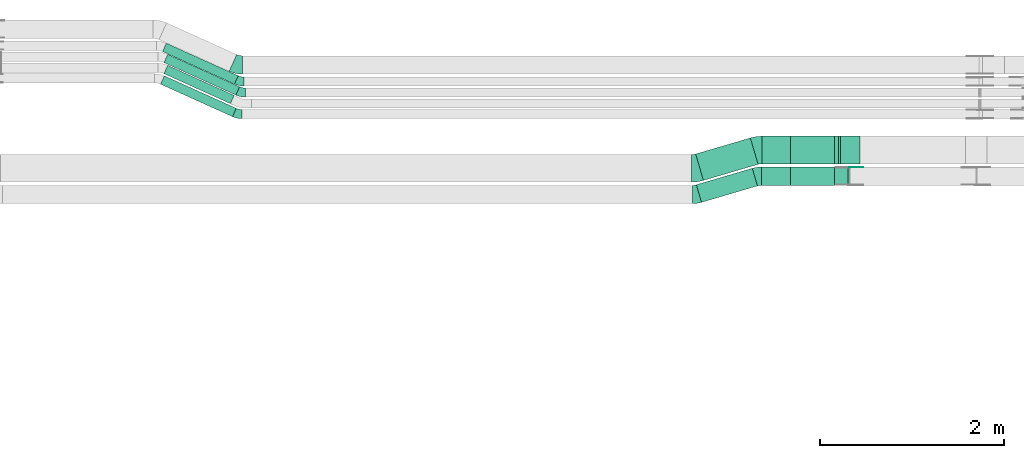
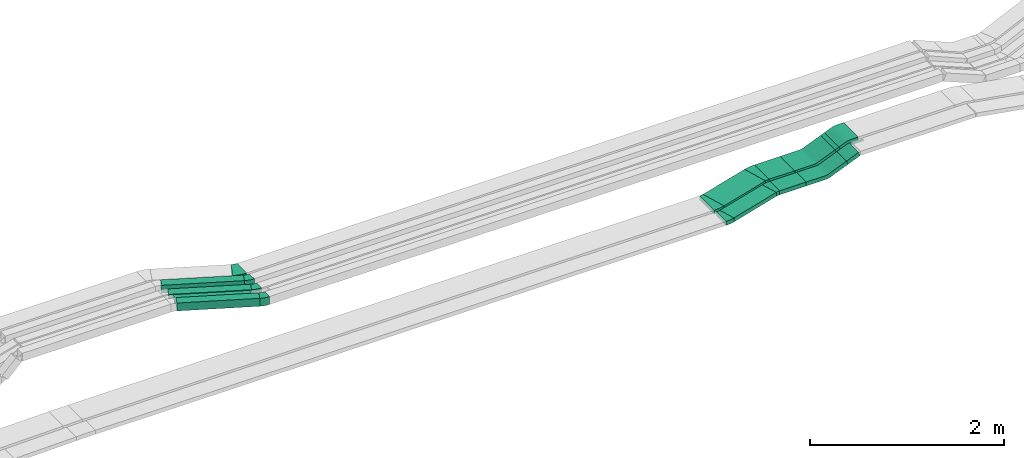
# One storey, part 14 of 31: 12 flow fittings, 10 flow segments.
"""IFC2X3 building model written with IfcOpenShell, lengths in millimetres."""

from ifc_helpers import new_model, entity, si_unit, converted_unit, derived_unit, direction, frame, frame_2d, origin, origin_2d_with_axis, place, context, subcontext, project, spatial, polyline, circle_curve, parameter, trimmed, segment, composite_curve, rectangle, outline, extrude, source, transform, mapped, material, type_object, type_shapes, element, save


model = new_model("IFC2X3")

# Units and contexts
model_context = context("Model", 3, precision=0.01, world=origin(), true_north=direction((6.12303176911189e-17, 1.0)))
body_context = subcontext(model_context, "Body", "Model", "MODEL_VIEW")
ifc_project = project(units=[si_unit("LENGTHUNIT", "METRE", prefix="MILLI"), si_unit("AREAUNIT", "SQUARE_METRE"), si_unit("VOLUMEUNIT", "CUBIC_METRE"), converted_unit("PLANEANGLEUNIT", "DEGREE", entity("IfcRatioMeasure", 0.0174532925199433), si_unit("PLANEANGLEUNIT", "RADIAN"), dimensions=[0, 0, 0, 0, 0, 0, 0]), si_unit("MASSUNIT", "GRAM", prefix="KILO"), derived_unit("MASSDENSITYUNIT", [(si_unit("MASSUNIT", "GRAM", prefix="KILO"), 1), (si_unit("LENGTHUNIT", "METRE"), -3)]), derived_unit("MOMENTOFINERTIAUNIT", [(si_unit("LENGTHUNIT", "METRE"), 4)]), si_unit("TIMEUNIT", "SECOND"), si_unit("FREQUENCYUNIT", "HERTZ"), si_unit("THERMODYNAMICTEMPERATUREUNIT", "DEGREE_CELSIUS"), derived_unit("THERMALTRANSMITTANCEUNIT", [(si_unit("MASSUNIT", "GRAM", prefix="KILO"), 1), (si_unit("THERMODYNAMICTEMPERATUREUNIT", "KELVIN"), -1), (si_unit("TIMEUNIT", "SECOND"), -3)]), derived_unit("VOLUMETRICFLOWRATEUNIT", [(si_unit("LENGTHUNIT", "METRE"), 3), (si_unit("TIMEUNIT", "SECOND"), -1)]), derived_unit("MASSFLOWRATEUNIT", [(si_unit("MASSUNIT", "GRAM", prefix="KILO"), 1), (si_unit("TIMEUNIT", "SECOND"), -1)]), derived_unit("ROTATIONALFREQUENCYUNIT", [(si_unit("TIMEUNIT", "SECOND"), -1)]), si_unit("ELECTRICCURRENTUNIT", "AMPERE"), si_unit("ELECTRICVOLTAGEUNIT", "VOLT"), si_unit("POWERUNIT", "WATT"), si_unit("FORCEUNIT", "NEWTON", prefix="KILO"), si_unit("ILLUMINANCEUNIT", "LUX"), si_unit("LUMINOUSFLUXUNIT", "LUMEN"), si_unit("LUMINOUSINTENSITYUNIT", "CANDELA"), derived_unit("USERDEFINED", [(si_unit("MASSUNIT", "GRAM", prefix="KILO"), -1), (si_unit("LENGTHUNIT", "METRE"), -2), (si_unit("TIMEUNIT", "SECOND"), 3), (si_unit("LUMINOUSFLUXUNIT", "LUMEN"), 1)]), derived_unit("LINEARVELOCITYUNIT", [(si_unit("LENGTHUNIT", "METRE"), 1), (si_unit("TIMEUNIT", "SECOND"), -1)]), si_unit("PRESSUREUNIT", "PASCAL"), derived_unit("USERDEFINED", [(si_unit("LENGTHUNIT", "METRE"), -2), (si_unit("MASSUNIT", "GRAM", prefix="KILO"), 1), (si_unit("TIMEUNIT", "SECOND"), -2)]), derived_unit("LINEARFORCEUNIT", [(si_unit("MASSUNIT", "GRAM", prefix="KILO"), 1), (si_unit("LENGTHUNIT", "METRE"), 1), (si_unit("TIMEUNIT", "SECOND"), -2), (si_unit("LENGTHUNIT", "METRE"), -1)]), derived_unit("PLANARFORCEUNIT", [(si_unit("MASSUNIT", "GRAM", prefix="KILO"), 1), (si_unit("LENGTHUNIT", "METRE"), 1), (si_unit("TIMEUNIT", "SECOND"), -2), (si_unit("LENGTHUNIT", "METRE"), -2)])], contexts=[model_context])

# Site, building, storey
site_placement = place(None, frame((0.0, -0.00077364408347762, 0.0)))
site = spatial("IfcSite", under=ifc_project, at=site_placement, CompositionType="ELEMENT")
building_placement = place(site_placement, origin())
building = spatial("IfcBuilding", under=site, at=building_placement, CompositionType="ELEMENT")
storey_placement = place(building_placement, frame((0.0, 0.0, 15900.0)))
storey = spatial("IfcBuildingStorey", under=building, at=storey_placement, CompositionType="ELEMENT", Elevation=15900.0)

# Flow segments
cable_carrier_segment_type = type_object("IfcCableCarrierSegmentType", PredefinedType="CABLETRAYSEGMENT")
flow_segment_1_placement = place(storey_placement, frame((42826.3964474229, 14635.0255085139, 2675.0)))
element("IfcFlowSegment", 1, at=flow_segment_1_placement, inside=storey, type_object=cable_carrier_segment_type, context=body_context, shape_type="SweptSolid", body=[
    extrude(rectangle(XDim=307.551244257685, YDim=300.000000000001, at=frame_2d((-4.32009983342141e-12, 0.0), x_axis=(1.0, 0.0))), frame((153.775622128847, 150.0, 0.0)), (0.0, 0.0, 1.0), 50.0000000000016),
])
flow_segment_2_placement = place(storey_placement, frame((42819.1959959563, 14400.0255085139, 2675.0)))
element("IfcFlowSegment", 2, at=flow_segment_2_placement, inside=storey, type_object=cable_carrier_segment_type, context=body_context, shape_type="SweptSolid", body=[
    extrude(rectangle(XDim=314.751695724342, YDim=199.999999999998, at=frame_2d((-4.33431068813661e-12, 0.0), x_axis=(1.0, 0.0))), frame((157.375847862167, 100.0, 0.0), z_axis=(0.0, 0.0, 1.0), x_axis=(-1.0, 0.0, 0.0)), (0.0, 0.0, 1.0), 50.0000000000016),
])
flow_segment_3_placement = place(storey_placement, frame((42109.4757953896, 14214.5297492879, 2675.0)))
element("IfcFlowSegment", 3, at=flow_segment_3_placement, inside=storey, type_object=cable_carrier_segment_type, context=body_context, shape_type="SweptSolid", body=[
    extrude(rectangle(XDim=634.797291199822, YDim=200.0, at=frame_2d((-3.12638803734444e-13, -1.03028696685215e-12), x_axis=(1.0, 0.0))), frame((332.717943233159, 185.495759225957, 0.0), z_axis=(0.0, 0.0, 1.0), x_axis=(-0.959365501571262, -0.282166323991578, 0.0)), (0.0, 0.0, 1.0), 50.0000000000016),
])
flow_segment_4_placement = place(storey_placement, frame((42102.275343923, 14453.5931991308, 2675.0)))
element("IfcFlowSegment", 4, at=flow_segment_4_placement, inside=storey, type_object=cable_carrier_segment_type, context=body_context, shape_type="SweptSolid", body=[
    extrude(rectangle(XDim=620.396388266396, YDim=299.999999999998, at=origin_2d_with_axis()), frame((339.918394699834, 231.432309383087, 0.0), z_axis=(0.0, 0.0, 1.0), x_axis=(0.959365501571253, 0.28216632399161, 0.0)), (0.0, 0.0, 1.0), 50.0000000000016),
])
flow_segment_5_placement = place(storey_placement, frame((43614.8135200623, 14635.0255085139, 2774.45618368983)))
element("IfcFlowSegment", 5, at=flow_segment_5_placement, inside=storey, type_object=cable_carrier_segment_type, context=body_context, shape_type="SweptSolid", body=[
    extrude(rectangle(XDim=49.9999999999987, YDim=48.6041297172027, at=frame_2d((-3.59001717242791e-12, -2.65742983174277e-12), x_axis=(0.0, 1.0))), frame((32.0192661297588, 0.0, 32.3969859064327), z_axis=(0.0, 1.0, 0.0), x_axis=(0.92387953251118, 0.0, 0.382683432365348)), (0.0, 0.0, 1.0), 300.000000000001),
])
flow_segment_6_placement = place(storey_placement, frame((43614.8135200624, 14400.0255085139, 2774.45618368983)))
element("IfcFlowSegment", 6, at=flow_segment_6_placement, inside=storey, type_object=cable_carrier_segment_type, context=body_context, shape_type="SweptSolid", body=[
    extrude(rectangle(XDim=49.9999999999987, YDim=156.412966816902, at=frame_2d((4.12114786740858e-13, -1.00008890058234e-12), x_axis=(0.0, 1.0))), frame((81.8204551398766, 0.0, 53.0253138167467), z_axis=(0.0, 1.0, 0.0), x_axis=(0.923879532511178, 0.0, 0.382683432365351)), (0.0, 0.0, 1.0), 199.999999999998),
])
flow_segment_7_placement = place(storey_placement, frame((36298.6071364209, 15502.5878894841, 2835.0)))
element("IfcFlowSegment", 7, at=flow_segment_7_placement, inside=storey, type_object=cable_carrier_segment_type, context=body_context, shape_type="SweptSolid", body=[
    extrude(rectangle(XDim=858.861846645775, YDim=100.000000000002, at=frame_2d((-1.96109795069788e-12, -8.98836560736527e-13), x_axis=(1.0, 0.0))), frame((411.918403549883, 222.40601951064, 0.0), z_axis=(0.0, 0.0, 1.0), x_axis=(-0.911271304124208, 0.411806520443479, 0.0)), (0.0, 0.0, 1.0), 99.9999999999989),
])
flow_segment_8_placement = place(storey_placement, frame((36314.0260386104, 15382.0519805412, 2838.00113012668)))
element("IfcFlowSegment", 8, at=flow_segment_8_placement, inside=storey, type_object=cable_carrier_segment_type, context=body_context, shape_type="SweptSolid", body=[
    extrude(rectangle(XDim=858.861846645806, YDim=100.000000000002, at=frame_2d((1.96109795069788e-12, 8.98836560736527e-13), x_axis=(1.0, 0.0))), frame((411.9184035499, 222.406019510648, 0.0), z_axis=(0.0, 0.0, 1.0), x_axis=(-0.911271304124206, 0.411806520443484, 0.0)), (0.0, 0.0, 1.0), 50.0000000000016),
])
flow_segment_9_placement = place(storey_placement, frame((36314.0260386104, 15289.0142820394, 2838.001130127)))
element("IfcFlowSegment", 9, at=flow_segment_9_placement, inside=storey, type_object=cable_carrier_segment_type, context=body_context, shape_type="SweptSolid", body=[
    extrude(rectangle(XDim=793.388620361837, YDim=100.000000000002, at=frame_2d((4.83169060316868e-13, -9.80548975348938e-13), x_axis=(1.0, 0.0))), frame((382.086467399393, 208.924868761544, 0.0), z_axis=(0.0, 0.0, 1.0), x_axis=(-0.911271304124207, 0.411806520443482, 0.0)), (0.0, 0.0, 1.0), 50.0000000000016),
])
flow_segment_10_placement = place(storey_placement, frame((36277.0343152676, 15147.5878390394, 2834.95472662277)))
element("IfcFlowSegment", 10, at=flow_segment_10_placement, inside=storey, type_object=cable_carrier_segment_type, context=body_context, shape_type="SweptSolid", body=[
    extrude(rectangle(XDim=858.861846434138, YDim=99.9999999996995, at=frame_2d((-1.96109795069788e-12, -8.95283847057726e-13), x_axis=(1.0, 0.0))), frame((411.918403452212, 222.406120532453, 0.0010539146473036), z_axis=(2.23645322951858e-06, -1.01066062150145e-06, 1.0), x_axis=(-0.911271304121465, 0.411806520442236, 2.45421228496595e-06)), (0.0, 0.0, 1.0), 99.999999999698),
])

# Flow fittings
ifc_material_1 = material(Name="G")
cable_carrier_fitting_type_1 = type_object("IfcCableCarrierFittingType", PredefinedType="NOTDEFINED", material=ifc_material_1)
shared_shape_1 = source(origin(), body_context, "Body", "SweptSolid", [
    extrude(outline(composite_curve([segment(trimmed(circle_curve(frame_2d((-44.5901162790698, 0.0), x_axis=(1.0, 0.0)), 12.5), [parameter(90.0000000000007)], [parameter(270.0)], True, "PARAMETER"), True, "CONTINUOUS"), segment(polyline([(-44.5901162790697, -12.5), (-33.0901162790698, -12.5)]), True, "CONTINUOUS"), segment(polyline([(-33.0901162790698, -12.5), (-31.2296511627907, -14.5)]), True, "CONTINUOUS"), segment(polyline([(-31.2296511627907, -14.5), (108.90988372093, -14.5)]), True, "CONTINUOUS"), segment(polyline([(108.90988372093, -14.5), (108.90988372093, 14.5)]), True, "CONTINUOUS"), segment(polyline([(108.90988372093, 14.5), (-31.2296511627907, 14.5)]), True, "CONTINUOUS"), segment(polyline([(-31.2296511627907, 14.5), (-33.0901162790698, 12.5)]), True, "CONTINUOUS"), segment(polyline([(-33.0901162790698, 12.5), (-44.5901162790699, 12.5)]), True, "CONTINUOUS")], self_intersect=False)), frame((44.5901162790698, 0.0, 0.0), z_axis=(0.0, 0.0, -1.0), x_axis=(1.0, 0.0, 0.0)), (0.0, 0.0, -1.0), 2.0),
])
type_shapes(cable_carrier_fitting_type_1, [shared_shape_1])
flow_fitting_1_placement = place(storey_placement, frame((43775.14058495, 14595.4855085241, 2860.0), z_axis=(0.0, 1.0, 0.0), x_axis=(1.0, 0.0, 0.0)))
element("IfcFlowFitting", 11, at=flow_fitting_1_placement, inside=storey, type_object=cable_carrier_fitting_type_1, material=ifc_material_1, context=body_context, shape_type="MappedRepresentation", body=[
    mapped(shared_shape_1, transform((0.0, 0.0, 0.0), scale=1.0)),
])
ifc_material_2 = material()
cable_carrier_fitting_type_2 = type_object("IfcCableCarrierFittingType", Name="470_DKC_S5_Variable Angle Elbow 0-45:-", PredefinedType="NOTDEFINED", material=ifc_material_2)
shared_shape_2 = source(origin(), body_context, "Body", "SweptSolid", [
    extrude(outline(composite_curve([segment(polyline([(-36.2606318743398, -105.149853884589), (-35.2606318743384, -105.149853884589)]), True, "CONTINUOUS"), segment(trimmed(circle_curve(frame_2d((-35.260631874333, 244.850146115411), x_axis=(0.0, -1.0)), 350.0), [parameter(0.0)], [parameter(16.3895403340349)], True, "PARAMETER"), True, "CONTINUOUS"), segment(polyline([(63.4975815227053, -90.9277794345345), (64.4569470242765, -90.645613110543)]), True, "CONTINUOUS"), segment(polyline([(64.4569470242765, -90.645613110543), (8.02368222596895, 101.227487203712)]), True, "CONTINUOUS"), segment(polyline([(8.02368222596895, 101.227487203712), (7.06431672439765, 100.94532087972)]), True, "CONTINUOUS"), segment(trimmed(circle_curve(frame_2d((-35.260631874333, 244.850146115411), x_axis=(0.0, -1.0)), 150.0), [parameter(0.0)], [parameter(16.3895403340349)], True, "PARAMETER"), False, "CONTINUOUS"), segment(polyline([(-35.260631874335, 94.8501461154113), (-36.2606318743364, 94.8501461154113)]), True, "CONTINUOUS"), segment(polyline([(-36.2606318743364, 94.8501461154113), (-36.2606318743398, -105.149853884589)]), True, "CONTINUOUS")], self_intersect=False)), frame((-0.741625459122476, 5.14985388458113, -25.0)), (0.0, 0.0, 1.0), 50.0000000000005),
])
type_shapes(cable_carrier_fitting_type_2, [shared_shape_2])
flow_fitting_2_placement = place(storey_placement, frame((42782.1937386228, 14500.0255085139, 2700.0), z_axis=(0.0, 0.0, 1.0), x_axis=(-1.0, 0.0, 0.0)))
element("IfcFlowFitting", 12, at=flow_fitting_2_placement, inside=storey, type_object=cable_carrier_fitting_type_2, material=ifc_material_2, Name="470_DKC_S5_Variable Angle Elbow 0-45:-", ObjectType="470_DKC_S5_Variable Angle Elbow 0-45:-", context=body_context, shape_type="MappedRepresentation", body=[
    mapped(shared_shape_2, transform((0.0, 0.0, 0.0), scale=1.0)),
])
flow_fitting_3_placement = place(storey_placement, frame((42102.1937386228, 14300.0255085139, 2700.0)))
element("IfcFlowFitting", 13, at=flow_fitting_3_placement, inside=storey, type_object=cable_carrier_fitting_type_2, material=ifc_material_2, Name="470_DKC_S5_Variable Angle Elbow 0-45:-", ObjectType="470_DKC_S5_Variable Angle Elbow 0-45:-", context=body_context, shape_type="MappedRepresentation", body=[
    mapped(shared_shape_2, transform((0.0, 0.0, 0.0), scale=1.0)),
])
cable_carrier_fitting_type_3 = type_object("IfcCableCarrierFittingType", Name="470_DKC_S5_Variable Angle Elbow 0-45:-", PredefinedType="NOTDEFINED", material=ifc_material_2)
shared_shape_3 = source(origin(), body_context, "Body", "SweptSolid", [
    extrude(outline(composite_curve([segment(polyline([(-43.3147899741278, -156.165716345309), (-42.3147899741262, -156.165716345309)]), True, "CONTINUOUS"), segment(trimmed(circle_curve(frame_2d((-42.3147899741345, 293.83428365469), x_axis=(0.0, -1.0)), 450.0), [parameter(0.0)], [parameter(16.3895403340363)], True, "PARAMETER"), True, "CONTINUOUS"), segment(polyline([(84.6600558220826, -137.880192052375), (85.6194213236537, -137.598025728384)]), True, "CONTINUOUS"), segment(polyline([(85.6194213236537, -137.598025728384), (0.969524126176022, 150.211624742994)]), True, "CONTINUOUS"), segment(polyline([(0.969524126176005, 150.211624742994), (0.0101586246045145, 149.929458419002)]), True, "CONTINUOUS"), segment(trimmed(circle_curve(frame_2d((-42.3147899741345, 293.83428365469), x_axis=(0.0, -1.0)), 150.0), [parameter(0.0)], [parameter(16.3895403340363)], True, "PARAMETER"), False, "CONTINUOUS"), segment(polyline([(-42.3147899741312, 143.834283654691), (-43.3147899741329, 143.834283654691)]), True, "CONTINUOUS"), segment(polyline([(-43.3147899741329, 143.834283654691), (-43.3147899741278, -156.165716345309)]), True, "CONTINUOUS")], self_intersect=False)), frame((-0.887918826025921, 6.16571634530042, -25.0)), (0.0, 0.0, 1.0), 49.9999999999995),
])
type_shapes(cable_carrier_fitting_type_3, [shared_shape_3])
flow_fitting_4_placement = place(storey_placement, frame((42102.1937386228, 14585.0255085139, 2700.0)))
element("IfcFlowFitting", 14, at=flow_fitting_4_placement, inside=storey, type_object=cable_carrier_fitting_type_3, material=ifc_material_2, Name="470_DKC_S5_Variable Angle Elbow 0-45:-", ObjectType="470_DKC_S5_Variable Angle Elbow 0-45:-", context=body_context, shape_type="MappedRepresentation", body=[
    mapped(shared_shape_3, transform((0.0, 0.0, 0.0), scale=1.0)),
])
flow_fitting_5_placement = place(storey_placement, frame((42782.1937386228, 14785.0255085139, 2700.0), z_axis=(0.0, 0.0, 1.0), x_axis=(-1.0, 0.0, 0.0)))
element("IfcFlowFitting", 15, at=flow_fitting_5_placement, inside=storey, type_object=cable_carrier_fitting_type_3, material=ifc_material_2, Name="470_DKC_S5_Variable Angle Elbow 0-45:-", ObjectType="470_DKC_S5_Variable Angle Elbow 0-45:-", context=body_context, shape_type="MappedRepresentation", body=[
    mapped(shared_shape_3, transform((0.0, 0.0, 0.0), scale=1.0)),
])
cable_carrier_fitting_type_4 = type_object("IfcCableCarrierFittingType", Name="470_DKC_S5_CS 90 internal vertical angle:-", PredefinedType="NOTDEFINED", material=ifc_material_2)
shared_shape_4 = source(origin(), body_context, "Body", "SweptSolid", [
    extrude(outline(composite_curve([segment(polyline([(-249.537644608747, -52.0525093627578), (-22.4666527522453, -52.0525093627578)]), True, "CONTINUOUS"), segment(trimmed(circle_curve(frame_2d((-22.4666527522457, 112.947490637241), x_axis=(0.0, -1.0)), 164.999999999999), [parameter(0.0)], [parameter(22.5)], True, "PARAMETER"), True, "CONTINUOUS"), segment(polyline([(40.676113587994, -39.4926322271201), (250.462355391253, 47.403674327071)]), True, "CONTINUOUS"), segment(polyline([(250.462355391253, 47.403674327071), (231.328183772998, 93.5976509526356)]), True, "CONTINUOUS"), segment(polyline([(231.328183772998, 93.5976509526356), (21.5419419697393, 6.70134439844441)]), True, "CONTINUOUS"), segment(trimmed(circle_curve(frame_2d((-22.4666527522457, 112.947490637241), x_axis=(0.0, -1.0)), 114.999999999999), [parameter(0.0)], [parameter(22.5)], True, "PARAMETER"), False, "CONTINUOUS"), segment(polyline([(-22.4666527522453, -2.05250936275757), (-249.537644608747, -2.05250936275755)]), True, "CONTINUOUS"), segment(polyline([(-249.537644608747, -2.05250936275755), (-249.537644608747, -52.0525093627578)]), True, "CONTINUOUS")], self_intersect=False)), frame((-5.38107868089768, 27.0525093627506, -150.0)), (0.0, 0.0, 1.0), 300.0),
])
type_shapes(cable_carrier_fitting_type_4, [shared_shape_4])
flow_fitting_6_placement = place(storey_placement, frame((43388.8664149703, 14785.0255085139, 2700.0), z_axis=(0.0, -1.0, 0.0), x_axis=(1.0, 0.0, 0.0)))
element("IfcFlowFitting", 16, at=flow_fitting_6_placement, inside=storey, type_object=cable_carrier_fitting_type_4, material=ifc_material_2, Name="470_DKC_S5_CS 90 internal vertical angle:-", ObjectType="470_DKC_S5_CS 90 internal vertical angle:-", context=body_context, shape_type="MappedRepresentation", body=[
    mapped(shared_shape_4, transform((0.0, 0.0, 0.0), scale=1.0)),
])
cable_carrier_fitting_type_5 = type_object("IfcCableCarrierFittingType", Name="470_DKC_S5_CS 90 internal vertical angle:-", PredefinedType="NOTDEFINED", material=ifc_material_2)
shared_shape_5 = source(origin(), body_context, "Body", "SweptSolid", [
    extrude(outline(composite_curve([segment(polyline([(-249.537644608747, -52.0525093627576), (-22.4666527522452, -52.0525093627576)]), True, "CONTINUOUS"), segment(trimmed(circle_curve(frame_2d((-22.4666527522456, 112.947490637241), x_axis=(0.0, -1.0)), 164.999999999999), [parameter(0.0)], [parameter(22.4999999999998)], True, "PARAMETER"), True, "CONTINUOUS"), segment(polyline([(40.6761135879937, -39.4926322271201), (250.462355391253, 47.4036743270706)]), True, "CONTINUOUS"), segment(polyline([(250.462355391253, 47.4036743270706), (231.328183772998, 93.5976509526352)]), True, "CONTINUOUS"), segment(polyline([(231.328183772998, 93.5976509526352), (21.5419419697391, 6.7013443984445)]), True, "CONTINUOUS"), segment(trimmed(circle_curve(frame_2d((-22.4666527522456, 112.947490637241), x_axis=(0.0, -1.0)), 114.999999999999), [parameter(0.0)], [parameter(22.4999999999998)], True, "PARAMETER"), False, "CONTINUOUS"), segment(polyline([(-22.4666527522452, -2.05250936275739), (-249.537644608747, -2.05250936275739)]), True, "CONTINUOUS"), segment(polyline([(-249.537644608747, -2.05250936275739), (-249.537644608747, -52.0525093627576)]), True, "CONTINUOUS")], self_intersect=False)), frame((-5.38107868089756, 27.0525093627503, -100.0)), (0.0, 0.0, 1.0), 200.0),
])
type_shapes(cable_carrier_fitting_type_5, [shared_shape_5])
flow_fitting_7_placement = place(storey_placement, frame((43388.8664149703, 14500.0255085139, 2700.0), z_axis=(0.0, -1.0, 0.0), x_axis=(1.0, 0.0, 0.0)))
element("IfcFlowFitting", 17, at=flow_fitting_7_placement, inside=storey, type_object=cable_carrier_fitting_type_5, material=ifc_material_2, Name="470_DKC_S5_CS 90 internal vertical angle:-", ObjectType="470_DKC_S5_CS 90 internal vertical angle:-", context=body_context, shape_type="MappedRepresentation", body=[
    mapped(shared_shape_5, transform((0.0, 0.0, 0.0), scale=1.0)),
])
cable_carrier_fitting_type_6 = type_object("IfcCableCarrierFittingType", Name="470_DKC_S5_CD 90 external vertical angle:-", PredefinedType="NOTDEFINED", material=ifc_material_2)
shared_shape_6 = source(origin(), body_context, "Body", "SweptSolid", [
    extrude(outline(composite_curve([segment(polyline([(-111.772297700764, -39.1016774864354), (-30.0155425647921, -39.1016774864354)]), True, "CONTINUOUS"), segment(trimmed(circle_curve(frame_2d((-30.0155425647923, 150.898322513563), x_axis=(0.0, -1.0)), 189.999999999999), [parameter(0.0)], [parameter(22.5)], True, "PARAMETER"), True, "CONTINUOUS"), segment(polyline([(42.6943095845745, -24.6387886635799), (118.227702299236, 6.6481670108859)]), True, "CONTINUOUS"), segment(polyline([(118.227702299236, 6.6481670108859), (99.0935306809812, 52.8421436364505)]), True, "CONTINUOUS"), segment(polyline([(99.0935306809812, 52.8421436364505), (23.5601379663198, 21.5551879619847)]), True, "CONTINUOUS"), segment(trimmed(circle_curve(frame_2d((-30.0155425647923, 150.898322513563), x_axis=(0.0, -1.0)), 139.999999999999), [parameter(0.0)], [parameter(22.5)], True, "PARAMETER"), False, "CONTINUOUS"), segment(polyline([(-30.0155425647921, 10.8983225135649), (-111.772297700764, 10.8983225135649)]), True, "CONTINUOUS"), segment(polyline([(-111.772297700764, 10.8983225135649), (-111.772297700764, -39.1016774864354)]), True, "CONTINUOUS")], self_intersect=False)), frame((-2.80499805284247, 14.1016774864282, -150.0)), (0.0, 0.0, 1.0), 300.0),
])
type_shapes(cable_carrier_fitting_type_6, [shared_shape_6])
flow_fitting_8_placement = place(storey_placement, frame((43775.1405849499, 14785.0255085139, 2860.0), z_axis=(0.0, 1.0, 0.0), x_axis=(0.92387953251118, 0.0, 0.382683432365348)))
element("IfcFlowFitting", 18, at=flow_fitting_8_placement, inside=storey, type_object=cable_carrier_fitting_type_6, material=ifc_material_2, Name="470_DKC_S5_CD 90 external vertical angle:-", ObjectType="470_DKC_S5_CD 90 external vertical angle:-", context=body_context, shape_type="MappedRepresentation", body=[
    mapped(shared_shape_6, transform((0.0, 0.0, 0.0), scale=1.0)),
])
cable_carrier_fitting_type_7 = type_object("IfcCableCarrierFittingType", Name="470_DKC_S5_Variable Angle Elbow 0-45:-", PredefinedType="NOTDEFINED", material=ifc_material_2)
shared_shape_7 = source(origin(), body_context, "Body", "SweptSolid", [
    extrude(outline(composite_curve([segment(polyline([(-52.4536328814624, -111.194038614583), (-51.453632881461, -111.194038614583)]), True, "CONTINUOUS"), segment(trimmed(circle_curve(frame_2d((-51.4536328814616, 238.805961385417), x_axis=(0.0, -1.0)), 350.0), [parameter(0.0)], [parameter(24.3183682159225)], True, "PARAMETER"), True, "CONTINUOUS"), segment(polyline([(92.6786492737437, -80.1389950580612), (93.5899205778679, -79.7271885376178)]), True, "CONTINUOUS"), segment(polyline([(93.5899205778679, -79.7271885376178), (11.2286164891793, 102.527072287227)]), True, "CONTINUOUS"), segment(polyline([(11.2286164891792, 102.527072287227), (10.317345185055, 102.115265766783)]), True, "CONTINUOUS"), segment(trimmed(circle_curve(frame_2d((-51.4536328814616, 238.805961385417), x_axis=(0.0, -1.0)), 150.0), [parameter(0.0)], [parameter(24.3183682159225)], True, "PARAMETER"), False, "CONTINUOUS"), segment(polyline([(-51.453632881461, 88.805961385417), (-52.4536328814624, 88.805961385417)]), True, "CONTINUOUS"), segment(polyline([(-52.4536328814624, 88.805961385417), (-52.4536328814624, -111.194038614583)]), True, "CONTINUOUS")], self_intersect=False)), frame((-2.41189101809613, 11.1940386145748, -50.0)), (0.0, 0.0, 1.0), 100.0),
])
type_shapes(cable_carrier_fitting_type_7, [shared_shape_7])
flow_fitting_9_placement = place(storey_placement, frame((37114.603272359, 15709.9939089947, 2885.0), z_axis=(0.0, 0.0, 1.0), x_axis=(0.911271304124217, -0.411806520443459, 0.0)))
element("IfcFlowFitting", 19, at=flow_fitting_9_placement, inside=storey, type_object=cable_carrier_fitting_type_7, material=ifc_material_2, Name="470_DKC_S5_Variable Angle Elbow 0-45:-", ObjectType="470_DKC_S5_Variable Angle Elbow 0-45:-", context=body_context, shape_type="MappedRepresentation", body=[
    mapped(shared_shape_7, transform((0.0, 0.0, 0.0), scale=1.0)),
])
cable_carrier_fitting_type_8 = type_object("IfcCableCarrierFittingType", Name="470_DKC_S5_Variable Angle Elbow 0-45:-", PredefinedType="NOTDEFINED", material=ifc_material_2)
shared_shape_8 = source(origin(), body_context, "Body", "SweptSolid", [
    extrude(outline(composite_curve([segment(polyline([(-42.1584698703778, -58.9758212176898), (-41.1584698703765, -58.9758212176898)]), True, "CONTINUOUS"), segment(trimmed(circle_curve(frame_2d((-41.1584698703791, 191.02417878231), x_axis=(0.0, -1.0)), 250.0), [parameter(0.0)], [parameter(24.3183682159238)], True, "PARAMETER"), True, "CONTINUOUS"), segment(polyline([(61.7931602404888, -36.7936472487425), (62.704431544613, -36.381840728299)]), True, "CONTINUOUS"), segment(polyline([(62.704431544613, -36.3818407282991), (21.5237795002658, 54.745289684122)]), True, "CONTINUOUS"), segment(polyline([(21.5237795002658, 54.745289684122), (20.6125081961416, 54.3334831636785)]), True, "CONTINUOUS"), segment(trimmed(circle_curve(frame_2d((-41.1584698703791, 191.02417878231), x_axis=(0.0, -1.0)), 150.0), [parameter(0.0)], [parameter(24.3183682159238)], True, "PARAMETER"), False, "CONTINUOUS"), segment(polyline([(-41.1584698703773, 41.0241787823101), (-42.1584698703787, 41.0241787823101)]), True, "CONTINUOUS"), segment(polyline([(-42.1584698703787, 41.0241787823101), (-42.1584698703778, -58.9758212176898)]), True, "CONTINUOUS")], self_intersect=False)), frame((-1.93394924926913, 8.97582121768134, -50.0)), (0.0, 0.0, 1.0), 100.0),
])
type_shapes(cable_carrier_fitting_type_8, [shared_shape_8])
flow_fitting_10_placement = place(storey_placement, frame((37142.0337737717, 15529.9939089947, 2885.0), z_axis=(0.0, 0.0, 1.0), x_axis=(0.911271304124212, -0.41180652044347, 0.0)))
element("IfcFlowFitting", 20, at=flow_fitting_10_placement, inside=storey, type_object=cable_carrier_fitting_type_8, material=ifc_material_2, Name="470_DKC_S5_Variable Angle Elbow 0-45:-", ObjectType="470_DKC_S5_Variable Angle Elbow 0-45:-", context=body_context, shape_type="MappedRepresentation", body=[
    mapped(shared_shape_8, transform((0.0, 0.0, 0.0), scale=1.0)),
])
cable_carrier_fitting_type_9 = type_object("IfcCableCarrierFittingType", Name="470_DKC_S5_Variable Angle Elbow 0-45:-", PredefinedType="NOTDEFINED", material=ifc_material_2)
shared_shape_9 = source(origin(), body_context, "Body", "SweptSolid", [
    extrude(outline(composite_curve([segment(polyline([(-42.1584698703783, -58.9758212176894), (-41.158469870377, -58.9758212176894)]), True, "CONTINUOUS"), segment(trimmed(circle_curve(frame_2d((-41.1584698703775, 191.02417878231), x_axis=(0.0, -1.0)), 250.0), [parameter(0.0)], [parameter(24.3183682159238)], True, "PARAMETER"), True, "CONTINUOUS"), segment(polyline([(61.7931602404885, -36.793647248743), (62.7044315446127, -36.3818407282996)]), True, "CONTINUOUS"), segment(polyline([(62.7044315446127, -36.3818407282996), (21.5237795002663, 54.7452896841218)]), True, "CONTINUOUS"), segment(polyline([(21.5237795002663, 54.7452896841218), (20.6125081961421, 54.3334831636783)]), True, "CONTINUOUS"), segment(trimmed(circle_curve(frame_2d((-41.1584698703775, 191.02417878231), x_axis=(0.0, -1.0)), 150.0), [parameter(0.0)], [parameter(24.3183682159238)], True, "PARAMETER"), False, "CONTINUOUS"), segment(polyline([(-41.158469870377, 41.0241787823105), (-42.1584698703783, 41.0241787823105)]), True, "CONTINUOUS"), segment(polyline([(-42.1584698703783, 41.0241787823105), (-42.1584698703783, -58.9758212176894)]), True, "CONTINUOUS")], self_intersect=False)), frame((-1.93394924926912, 8.97582121768133, -25.0)), (0.0, 0.0, 1.0), 50.0),
])
type_shapes(cable_carrier_fitting_type_9, [shared_shape_9])
flow_fitting_11_placement = place(storey_placement, frame((37157.4526759612, 15409.4580000518, 2863.00113012668), z_axis=(0.0, 0.0, 1.0), x_axis=(0.911271304124212, -0.41180652044347, 0.0)))
element("IfcFlowFitting", 21, at=flow_fitting_11_placement, inside=storey, type_object=cable_carrier_fitting_type_9, material=ifc_material_2, Name="470_DKC_S5_Variable Angle Elbow 0-45:-", ObjectType="470_DKC_S5_Variable Angle Elbow 0-45:-", context=body_context, shape_type="MappedRepresentation", body=[
    mapped(shared_shape_9, transform((0.0, 0.0, 0.0), scale=1.0)),
])
cable_carrier_fitting_type_10 = type_object("IfcCableCarrierFittingType", Name="470_DKC_S5_Variable Angle Elbow 0-45:-", PredefinedType="NOTDEFINED", material=ifc_material_2)
shared_shape_10 = source(origin(), body_context, "Body", "SweptSolid", [
    extrude(outline(composite_curve([segment(polyline([(-42.1584701005356, -58.9758213223925), (-41.1584701005342, -58.9758213223925)]), True, "CONTINUOUS"), segment(trimmed(circle_curve(frame_2d((-41.1584701005368, 191.024178677607), x_axis=(0.0, -1.0)), 250.0), [parameter(0.0)], [parameter(24.3183683607981)], True, "PARAMETER"), True, "CONTINUOUS"), segment(polyline([(61.7931605863762, -36.7936470931285), (62.7044318894592, -36.3818405703809)]), True, "CONTINUOUS"), segment(polyline([(62.7044318894592, -36.3818405703808), (21.5237796146939, 54.7452897379134)]), True, "CONTINUOUS"), segment(polyline([(21.5237796146939, 54.7452897379134), (20.612508311611, 54.3334832151658)]), True, "CONTINUOUS"), segment(trimmed(circle_curve(frame_2d((-41.1584701005368, 191.024178677607), x_axis=(0.0, -1.0)), 150.0), [parameter(0.0)], [parameter(24.3183683607981)], True, "PARAMETER"), False, "CONTINUOUS"), segment(polyline([(-41.1584701005351, 41.0241786776074), (-42.1584701005364, 41.0241786776074)]), True, "CONTINUOUS"), segment(polyline([(-42.1584701005364, 41.0241786776074), (-42.1584701005356, -58.9758213223925)]), True, "CONTINUOUS")], self_intersect=False)), frame((-1.93394928370324, 8.97582132238407, -50.0)), (0.0, 0.0, 1.0), 100.0),
])
type_shapes(cable_carrier_fitting_type_10, [shared_shape_10])
flow_fitting_12_placement = place(storey_placement, frame((37120.461064441, 15174.9939089947, 2884.95683445176), z_axis=(0.0, 0.000116085582501322, 0.999999993262069), x_axis=(0.911271303082948, -0.411806519972919, 4.78048000710039e-05)))
element("IfcFlowFitting", 22, at=flow_fitting_12_placement, inside=storey, type_object=cable_carrier_fitting_type_10, material=ifc_material_2, Name="470_DKC_S5_Variable Angle Elbow 0-45:-", ObjectType="470_DKC_S5_Variable Angle Elbow 0-45:-", context=body_context, shape_type="MappedRepresentation", body=[
    mapped(shared_shape_10, transform((0.0, 0.0, 0.0), scale=1.0)),
])

save(model, "model.ifc")
